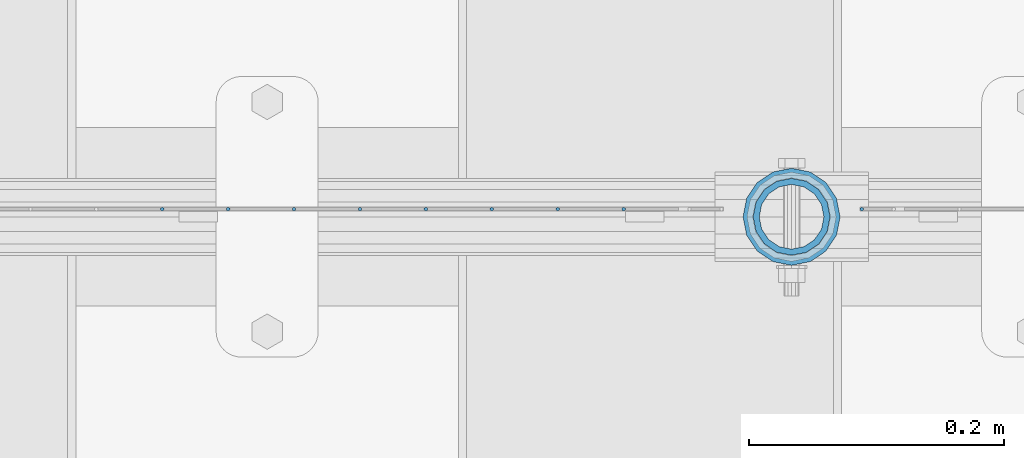
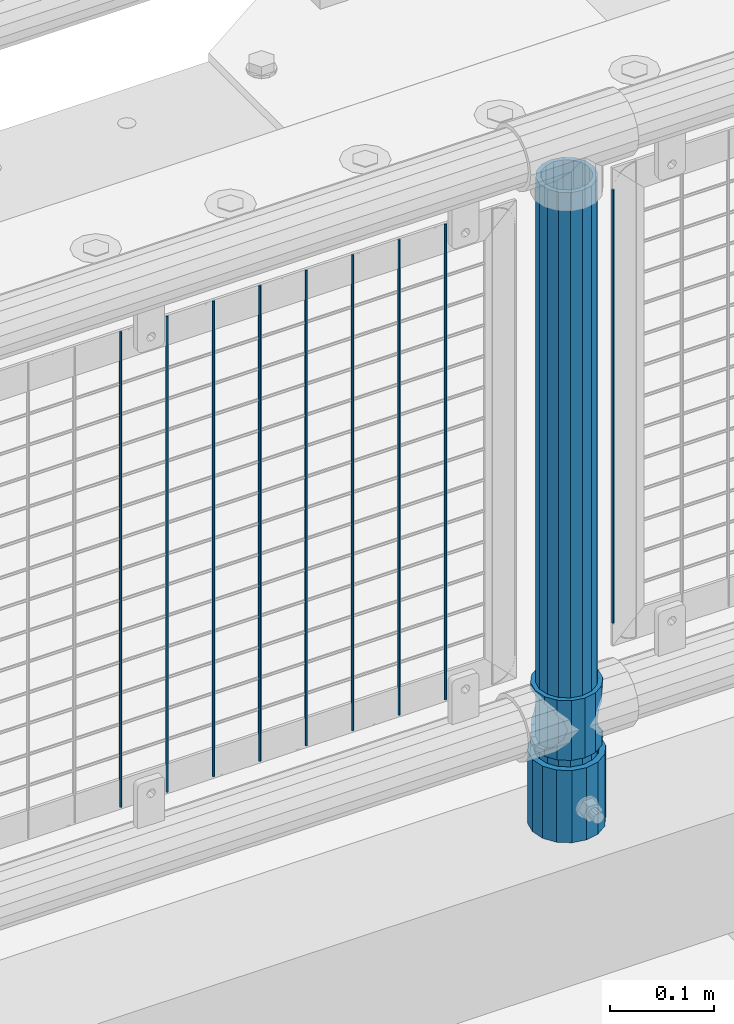
# One storey, part 81 of 219: 12 columns.
"""IFC2X3 building model written with IfcOpenShell, lengths in millimetres."""

from ifc_helpers import new_model, si_unit, frame, origin_with_axes, place, context, subcontext, project, spatial, faceted_brep, material, type_object, element, save


model = new_model("IFC2X3")

# Units and contexts
model_context = context("Model", 3, precision=1e-05, world=origin_with_axes())
body_context = subcontext(model_context, "Body", "Model", "MODEL_VIEW")
ifc_project = project(units=[si_unit("LENGTHUNIT", "METRE", prefix="MILLI"), si_unit("AREAUNIT", "SQUARE_METRE"), si_unit("VOLUMEUNIT", "CUBIC_METRE"), si_unit("MASSUNIT", "GRAM", prefix="KILO"), si_unit("TIMEUNIT", "SECOND"), si_unit("PLANEANGLEUNIT", "RADIAN"), si_unit("SOLIDANGLEUNIT", "STERADIAN"), si_unit("THERMODYNAMICTEMPERATUREUNIT", "DEGREE_CELSIUS"), si_unit("LUMINOUSINTENSITYUNIT", "LUMEN")], contexts=[model_context])

# Site, building, storey
site_placement = place(None, origin_with_axes())
site = spatial("IfcSite", under=ifc_project, at=site_placement, CompositionType="ELEMENT")
building_placement = place(site_placement, origin_with_axes())
building = spatial("IfcBuilding", under=site, at=building_placement, Name="Standard", CompositionType="ELEMENT")
storey_placement = place(building_placement, origin_with_axes())
storey = spatial("IfcBuildingStorey", under=building, at=storey_placement, Name="Undefined", CompositionType="ELEMENT", Elevation=0.0)

# Columns
ifc_material_1 = material(Name="Misc_Undefined")
column_type_1 = type_object("IfcColumnType", PredefinedType="NOTDEFINED")
column_1_placement = place(storey_placement, frame((8911.0, 31664.5, 263.02), z_axis=(-1.0, 0.0, 0.0), x_axis=(0.0, 0.0, 1.0)))
element("IfcColumn", 1, at=column_1_placement, inside=storey, type_object=column_type_1, material=ifc_material_1, context=body_context, shape_type="Brep", body=[
    faceted_brep([(56.6106908090114, 21.46069080901, -21.4606908090118), (56.6106908090114, 21.46069080901, -27.1226768591096), (61.9623795176703, 13.4513226476338, -32.4743655677721), (63.1897438117172, 11.614442172282, -32.8397438117172), (63.1897438117172, 11.614442172282, -28.0397438117179), (46.7644421722801, 28.0397438117179, -11.6144421722802), (46.7644421722801, 28.0397438117179, -20.0882031229849), (51.5310424080006, 24.8548033587067, -24.8548033587067), (35.1499999999996, 30.35, 0.0), (35.1499999999996, 30.3499999999985, -16.6306603983739), (23.5355578277192, 28.0397438117179, -11.6144421722802), (23.5355578277192, 28.0397438117179, -20.0882031229849), (13.6893091909879, 21.46069080901, -21.4606908090118), (13.6893091909879, 21.46069080901, -27.1226768591096), (18.7689575919987, 24.8548033587067, -24.8548033587067), (7.11025618828211, 11.614442172282, -28.0397438117179), (7.11025618828211, 11.614442172282, -32.8397438117172), (8.33762048232455, 13.4513226476338, -32.4743655677721), (4.79999999999961, 0.0, -30.3500000000004), (4.79999999999961, 0.0, -35.1499999999996), (7.11025618828211, -11.614442172282, -28.0397438117179), (7.11025618828211, -11.614442172282, -32.839743811719), (13.6893091909879, -21.46069080901, -21.4606908090118), (13.6893091909879, -21.46069080901, -27.1226768591077), (8.33762048232455, -13.4513226476338, -32.4743655677721), (23.5355578277191, -28.0397438117179, -11.6144421722802), (23.5355578277191, -28.0397438117179, -20.0882031229739), (18.7689575919921, -24.8548033587067, -24.8548033587067), (35.1499999999996, -30.35, 0.0), (35.1499999999996, -30.3499999999985, -16.6306603983649), (46.7644421722801, -28.0397438117179, -11.6144421722802), (46.7644421722801, -28.0397438117179, -20.0882031229739), (56.6106908090114, -21.46069080901, -21.4606908090118), (56.6106908090114, -21.46069080901, -27.1226768591077), (51.5310424080006, -24.8548033587067, -24.8548033587067), (63.1897438117172, -11.614442172282, -28.0397438117179), (63.1897438117172, -11.614442172282, -32.839743811719), (61.9623795176747, -13.4513226476338, -32.4743655677721), (65.4999999999997, 0.0, -30.3500000000004), (65.4999999999997, 0.0, -35.1499999999996), (0.0, -28.0397438117179, -11.6144421722802), (0.0, -30.3499999999985, 0.0), (0.0, -21.46069080901, -21.4606908090118), (0.0, -11.614442172282, -28.0397438117179), (0.0, 0.0, -30.3500000000004), (0.0, 11.614442172282, -28.0397438117179), (0.0, 21.46069080901, -21.4606908090118), (0.0, 28.0397438117179, -11.6144421722802), (0.0, 30.3499999999985, 0.0), (0.0, 28.0397438117179, 11.6144421722802), (23.5355578277192, 28.0397438117179, 11.6144421722806), (0.0, 21.46069080901, 21.4606908090118), (13.6893091909879, 21.46069080901, 21.4606908090118), (0.0, 11.614442172282, 28.0397438117179), (7.11025618828211, 11.614442172282, 28.0397438117175), (0.0, 0.0, 30.3500000000004), (4.79999999999961, 0.0, 30.3499999999999), (0.0, -11.614442172282, 28.0397438117179), (7.11025618828205, -11.614442172282, 28.0397438117175), (0.0, -21.46069080901, 21.4606908090118), (13.6893091909879, -21.46069080901, 21.4606908090118), (0.0, -28.0397438117179, 11.6144421722802), (23.5355578277191, -28.0397438117179, 11.6144421722806), (0.0, -32.4743655677703, 13.4513226476338), (0.0, -35.1500000000015, 0.0), (70.2999999999993, -35.1500000000015, 0.0), (70.2999999999993, -32.4743655677703, 13.4513226476338), (0.0, 13.4513226476338, -32.4743655677721), (0.0, 24.8548033587067, -24.8548033587067), (0.0, 0.0, -35.1500000000015), (0.0, -13.4513226476338, -32.4743655677721), (0.0, -24.8548033587067, -24.8548033587067), (0.0, -24.8548033587067, 24.8548033587067), (0.0, -13.4513226476338, 32.4743655677721), (0.0, 0.0, 35.1500000000015), (0.0, 13.4513226476338, 32.4743655677721), (0.0, 24.8548033587067, 24.8548033587067), (0.0, 32.4743655677703, 13.4513226476338), (0.0, 35.1500000000015, 0.0), (0.0, 32.4743655677703, -13.4513226476338), (0.0, -32.4743655677703, -13.4513226476338), (70.2999999999993, 32.4743655677703, 13.4513226476338), (70.2999999999993, 35.1500000000015, 0.0), (70.2999999999993, 32.4743655677703, -13.4513226476338), (70.2999999999993, 24.8548033587067, -24.8548033587067), (70.2999999999993, 13.4513226476338, -32.4743655677721), (70.2999999999993, 0.0, -35.1499999999996), (70.2999999999993, -13.4513226476338, -32.4743655677721), (70.2999999999993, -24.8548033587067, -24.8548033587067), (70.2999999999993, -32.4743655677703, -13.4513226476338), (70.2999999999993, 28.0397438117179, 11.6144421722802), (70.2999999999993, 21.46069080901, 21.4606908090118), (56.6106908090114, 21.46069080901, 21.4606908090118), (46.7644421722801, 28.0397438117179, 11.6144421722806), (70.2999999999993, 11.614442172282, 28.0397438117179), (63.1897438117172, 11.614442172282, 28.0397438117175), (70.2999999999993, 0.0, 30.3500000000004), (65.4999999999997, 0.0, 30.3499999999999), (70.2999999999993, -11.614442172282, 28.0397438117179), (63.1897438117172, -11.614442172282, 28.0397438117175), (70.2999999999993, -21.46069080901, 21.4606908090118), (56.6106908090114, -21.46069080901, 21.4606908090118), (70.2999999999993, -28.0397438117179, 11.6144421722802), (46.7644421722801, -28.0397438117179, 11.6144421722806), (70.2999999999993, -11.614442172282, -28.0397438117179), (70.2999999999993, 0.0, -30.3500000000004), (70.2999999999993, -21.46069080901, -21.4606908090118), (70.2999999999993, -28.0397438117179, -11.6144421722802), (70.2999999999993, -30.3499999999985, 0.0), (70.2999999999993, 24.8548033587067, 24.8548033587067), (70.2999999999993, 13.4513226476338, 32.4743655677721), (70.2999999999993, 0.0, 35.1499999999996), (70.2999999999993, -13.4513226476338, 32.4743655677721), (70.2999999999993, -24.8548033587067, 24.8548033587067), (70.2999999999993, 30.3499999999985, 0.0), (70.2999999999993, 28.0397438117179, -11.6144421722802), (70.2999999999993, 21.46069080901, -21.4606908090118), (70.2999999999993, 11.614442172282, -28.0397438117179), (61.9623795176742, 13.4513226476338, 32.4743655677717), (51.5310424080006, 24.8548033587067, 24.8548033587072), (56.6106908090114, 21.46069080901, 27.1226768591059), (65.4999999999997, 0.0, 35.1500000000001), (63.1897438117172, 11.614442172282, 32.8397438117177), (63.1897438117172, -11.614442172282, 32.8397438117177), (61.9623795176742, -13.4513226476338, 32.4743655677717), (56.6106908090114, -21.46069080901, 27.1226768591087), (51.5310424080006, -24.8548033587067, 24.8548033587072), (18.7689575919921, -24.8548033587067, 24.8548033587072), (46.7644421722801, -28.0397438117179, 20.0882031229862), (35.1499999999996, -30.3499999999985, 16.630660398373), (23.5355578277191, -28.0397438117179, 20.0882031229862), (8.33762048232506, -13.4513226476338, 32.4743655677717), (13.6893091909879, -21.46069080901, 27.1226768591087), (4.79999999999961, 0.0, 35.1500000000001), (7.11025618828205, -11.614442172282, 32.8397438117177), (7.11025618828211, 11.614442172282, 32.8397438117177), (8.33762048232069, 13.4513226476338, 32.4743655677717), (13.6893091909879, 21.46069080901, 27.1226768591059), (18.7689575919987, 24.8548033587067, 24.8548033587072), (23.5355578277192, 28.0397438117179, 20.0882031229794), (35.1499999999996, 30.3499999999985, 16.6306603983667), (46.7644421722801, 28.0397438117179, 20.0882031229794)], [[[0, 1, 2, 3, 4]], [[5, 6, 7, 1, 0]], [[8, 9, 6, 5]], [[10, 11, 9, 8]], [[12, 13, 14, 11, 10]], [[15, 16, 17, 13, 12]], [[18, 19, 16, 15]], [[20, 21, 19, 18]], [[22, 23, 24, 21, 20]], [[25, 26, 27, 23, 22]], [[28, 29, 26, 25]], [[30, 31, 29, 28]], [[32, 33, 34, 31, 30]], [[35, 36, 37, 33, 32]], [[38, 39, 36, 35]], [[4, 3, 39, 38]], [[40, 41, 28, 25]], [[42, 40, 25, 22]], [[43, 42, 22, 20]], [[44, 43, 20, 18]], [[45, 44, 18, 15]], [[46, 45, 15, 12]], [[47, 46, 12, 10]], [[48, 47, 10, 8]], [[49, 48, 8, 50]], [[51, 49, 50, 52]], [[53, 51, 52, 54]], [[55, 53, 54, 56]], [[57, 55, 56, 58]], [[59, 57, 58, 60]], [[61, 59, 60, 62]], [[41, 61, 62, 28]], [[63, 64, 65, 66]], [[17, 67, 68, 14, 13]], [[19, 69, 67, 17, 16]], [[70, 69, 19, 21, 24]], [[71, 70, 24, 23, 27]], [[63, 72, 73, 74, 75, 76, 77, 78, 79, 68, 67, 69, 70, 71, 80, 64], [40, 42, 43, 44, 45, 46, 47, 48, 49, 51, 53, 55, 57, 59, 61, 41]], [[78, 77, 81, 82]], [[79, 78, 82, 83]], [[14, 68, 79, 83, 84, 7, 6, 9, 11]], [[84, 85, 2, 1, 7]], [[85, 86, 39, 3, 2]], [[37, 87, 88, 34, 33]], [[39, 86, 87, 37, 36]], [[34, 88, 89, 80, 71, 27, 26, 29, 31]], [[64, 80, 89, 65]], [[90, 91, 92, 93]], [[91, 94, 95, 92]], [[94, 96, 97, 95]], [[96, 98, 99, 97]], [[98, 100, 101, 99]], [[100, 102, 103, 101]], [[104, 105, 38, 35]], [[106, 104, 35, 32]], [[107, 106, 32, 30]], [[108, 107, 30, 28]], [[102, 108, 28, 103]], [[88, 87, 86, 85, 84, 83, 82, 81, 109, 110, 111, 112, 113, 66, 65, 89], [100, 98, 96, 94, 91, 90, 114, 115, 116, 117, 105, 104, 106, 107, 108, 102]], [[118, 110, 109, 119, 120]], [[121, 111, 110, 118, 122]], [[112, 111, 121, 123, 124]], [[113, 112, 124, 125, 126]], [[127, 72, 63, 66, 113, 126, 128, 129, 130]], [[131, 73, 72, 127, 132]], [[133, 74, 73, 131, 134]], [[75, 74, 133, 135, 136]], [[76, 75, 136, 137, 138]], [[119, 109, 81, 77, 76, 138, 139, 140, 141]], [[92, 120, 119, 141, 93]], [[95, 122, 118, 120, 92]], [[97, 121, 122, 95]], [[99, 123, 121, 97]], [[101, 125, 124, 123, 99]], [[103, 128, 126, 125, 101]], [[28, 129, 128, 103]], [[62, 130, 129, 28]], [[60, 132, 127, 130, 62]], [[58, 134, 131, 132, 60]], [[56, 133, 134, 58]], [[54, 135, 133, 56]], [[52, 137, 136, 135, 54]], [[50, 139, 138, 137, 52]], [[8, 140, 139, 50]], [[93, 141, 140, 8]], [[114, 90, 93, 8]], [[115, 114, 8, 5]], [[116, 115, 5, 0]], [[117, 116, 0, 4]], [[105, 117, 4, 38]]]),
])
ifc_material_2 = material()
column_type_2 = type_object("IfcColumnType", PredefinedType="NOTDEFINED")
column_2_placement = place(storey_placement, frame((8911.0, 31664.5, 168.02), z_axis=(-1.0, 0.0, 0.0), x_axis=(0.0, 0.0, 1.0)))
element("IfcColumn", 2, at=column_2_placement, inside=storey, type_object=column_type_2, material=ifc_material_2, context=body_context, shape_type="Brep", body=[
    faceted_brep([(0.0, -25.3499999999985, 0.0), (0.0, -23.4203461491597, 9.70102501045585), (760.0, -23.4203461491597, 9.70102501045585), (760.0, -25.3499999999985, 0.0), (0.0, -17.9251569030785, 17.9251569030785), (760.0, -17.9251569030785, 17.9251569030785), (0.0, -9.70102501045403, 23.4203461491616), (760.0, -9.70102501045403, 23.4203461491616), (0.0, 0.0, 25.3500000000004), (760.0, 0.0, 25.3500000000004), (0.0, 9.70102501045403, 23.4203461491616), (760.0, 9.70102501045403, 23.4203461491616), (0.0, 17.9251569030785, 17.9251569030785), (760.0, 17.9251569030785, 17.9251569030785), (0.0, 23.4203461491597, 9.70102501045585), (760.0, 23.4203461491597, 9.70102501045585), (0.0, 25.3499999999985, 0.0), (760.0, 25.3499999999985, 0.0), (0.0, 23.4203461491597, -9.70102501045585), (760.0, 23.4203461491597, -9.70102501045585), (0.0, 17.9251569030785, -17.9251569030785), (760.0, 17.9251569030785, -17.9251569030785), (0.0, 9.70102501045403, -23.4203461491616), (760.0, 9.70102501045403, -23.4203461491616), (0.0, 0.0, -25.3500000000004), (760.0, 0.0, -25.3500000000004), (0.0, -9.70102501045403, -23.4203461491616), (760.0, -9.70102501045403, -23.4203461491616), (0.0, -17.9251569030785, -17.9251569030785), (760.0, -17.9251569030785, -17.9251569030785), (0.0, -23.4203461491597, -9.70102501045585), (760.0, -23.4203461491597, -9.70102501045585), (0.0, -30.1500000000015, 0.0), (0.0, -27.8549679052157, -11.5379054858076), (760.0, -27.8549679052157, -11.5379054858076), (760.0, -30.1500000000015, 0.0), (0.0, -21.3192694527752, -21.3192694527752), (760.0, -21.3192694527752, -21.3192694527752), (0.0, -11.5379054858058, -27.8549679052157), (760.0, -11.5379054858058, -27.8549679052157), (0.0, 0.0, -30.1499999999996), (760.0, 0.0, -30.1499999999996), (0.0, 11.5379054858058, -27.8549679052157), (760.0, 11.5379054858058, -27.8549679052157), (0.0, 21.3192694527752, -21.3192694527752), (760.0, 21.3192694527752, -21.3192694527752), (0.0, 27.8549679052157, -11.5379054858076), (760.0, 27.8549679052157, -11.5379054858076), (0.0, 30.1500000000015, 0.0), (760.0, 30.1500000000015, 0.0), (0.0, 27.8549679052157, 11.5379054858076), (760.0, 27.8549679052157, 11.5379054858076), (0.0, 21.3192694527752, 21.3192694527752), (760.0, 21.3192694527752, 21.3192694527752), (0.0, 11.5379054858058, 27.8549679052157), (760.0, 11.5379054858058, 27.8549679052157), (0.0, 0.0, 30.1499999999996), (760.0, 0.0, 30.1499999999996), (0.0, -11.5379054858058, 27.8549679052157), (760.0, -11.5379054858058, 27.8549679052157), (0.0, -21.3192694527752, 21.3192694527752), (760.0, -21.3192694527752, 21.3192694527752), (0.0, -27.8549679052157, 11.5379054858076), (760.0, -27.8549679052157, 11.5379054858076)], [[[0, 1, 2, 3]], [[1, 4, 5, 2]], [[4, 6, 7, 5]], [[6, 8, 9, 7]], [[8, 10, 11, 9]], [[10, 12, 13, 11]], [[12, 14, 15, 13]], [[14, 16, 17, 15]], [[16, 18, 19, 17]], [[18, 20, 21, 19]], [[20, 22, 23, 21]], [[22, 24, 25, 23]], [[24, 26, 27, 25]], [[26, 28, 29, 27]], [[28, 30, 31, 29]], [[30, 0, 3, 31]], [[32, 33, 34, 35]], [[33, 36, 37, 34]], [[36, 38, 39, 37]], [[38, 40, 41, 39]], [[40, 42, 43, 41]], [[42, 44, 45, 43]], [[44, 46, 47, 45]], [[46, 48, 49, 47]], [[48, 50, 51, 49]], [[50, 52, 53, 51]], [[52, 54, 55, 53]], [[54, 56, 57, 55]], [[56, 58, 59, 57]], [[58, 60, 61, 59]], [[60, 62, 63, 61]], [[62, 32, 35, 63]], [[37, 39, 41, 43, 45, 47, 49, 51, 53, 55, 57, 59, 61, 63, 35, 34], [5, 7, 9, 11, 13, 15, 17, 19, 21, 23, 25, 27, 29, 31, 3, 2]], [[62, 60, 58, 56, 54, 52, 50, 48, 46, 44, 42, 40, 38, 36, 33, 32], [30, 28, 26, 24, 22, 20, 18, 16, 14, 12, 10, 8, 6, 4, 1, 0]]]),
])
column_type_3 = type_object("IfcColumnType", PredefinedType="NOTDEFINED")
column_3_placement = place(storey_placement, frame((8911.0, 31664.5, 168.02), z_axis=(0.0, 1.0, 0.0), x_axis=(0.0, 0.0, 1.0)))
element("IfcColumn", 3, at=column_3_placement, inside=storey, type_object=column_type_3, material=ifc_material_2, context=body_context, shape_type="Brep", body=[
    faceted_brep([(0.0, -31.75, 0.0), (0.0, -29.3331751572332, 12.1501989775934), (85.0, -29.3331751572332, 12.1501989775934), (85.0, -31.75, 0.0), (0.0, -22.4506403026735, 22.4506403026717), (85.0, -22.4506403026735, 22.4506403026717), (0.0, -12.1501989775916, 29.3331751572332), (85.0, -12.1501989775916, 29.3331751572332), (0.0, 0.0, 31.75), (85.0, 0.0, 31.75), (0.0, 12.1501989775916, 29.3331751572332), (85.0, 12.1501989775916, 29.3331751572332), (0.0, 22.4506403026735, 22.4506403026717), (85.0, 22.4506403026735, 22.4506403026717), (0.0, 29.3331751572332, 12.1501989775934), (85.0, 29.3331751572332, 12.1501989775934), (0.0, 31.75, 0.0), (85.0, 31.75, 0.0), (0.0, 29.3331751572332, -12.1501989775934), (85.0, 29.3331751572332, -12.1501989775934), (0.0, 22.4506403026735, -22.4506403026717), (85.0, 22.4506403026735, -22.4506403026717), (0.0, 12.1501989775916, -29.3331751572332), (85.0, 12.1501989775916, -29.3331751572332), (0.0, 0.0, -31.75), (85.0, 0.0, -31.75), (0.0, -12.1501989775916, -29.3331751572332), (85.0, -12.1501989775916, -29.3331751572332), (0.0, -22.4506403026735, -22.4506403026717), (85.0, -22.4506403026735, -22.4506403026717), (0.0, -29.3331751572332, -12.1501989775934), (85.0, -29.3331751572332, -12.1501989775934), (0.0, -38.0499999999993, 0.0), (0.0, -35.1536162120537, -14.5611046014928), (85.0, -35.1536162120537, -14.5611046014928), (85.0, -38.0499999999993, 0.0), (0.0, -26.9054130241475, -26.9054130241493), (85.0, -26.9054130241475, -26.9054130241493), (0.0, -14.561104601491, -35.1536162120537), (85.0, -14.561104601491, -35.1536162120537), (0.0, 0.0, -38.0499999999993), (85.0, 0.0, -38.0499999999993), (0.0, 14.561104601491, -35.1536162120537), (85.0, 14.561104601491, -35.1536162120537), (0.0, 26.9054130241475, -26.9054130241493), (85.0, 26.9054130241475, -26.9054130241493), (0.0, 35.1536162120537, -14.5611046014928), (85.0, 35.1536162120537, -14.5611046014928), (0.0, 38.0499999999993, 0.0), (85.0, 38.0499999999993, 0.0), (0.0, 35.1536162120537, 14.5611046014928), (85.0, 35.1536162120537, 14.5611046014928), (0.0, 26.9054130241475, 26.9054130241493), (85.0, 26.9054130241475, 26.9054130241493), (0.0, 14.561104601491, 35.1536162120537), (85.0, 14.561104601491, 35.1536162120537), (0.0, 0.0, 38.0499999999993), (85.0, 0.0, 38.0499999999993), (0.0, -14.561104601491, 35.1536162120537), (85.0, -14.561104601491, 35.1536162120537), (0.0, -26.9054130241475, 26.9054130241493), (85.0, -26.9054130241475, 26.9054130241493), (0.0, -35.1536162120537, 14.5611046014928), (85.0, -35.1536162120537, 14.5611046014928)], [[[0, 1, 2, 3]], [[1, 4, 5, 2]], [[4, 6, 7, 5]], [[6, 8, 9, 7]], [[8, 10, 11, 9]], [[10, 12, 13, 11]], [[12, 14, 15, 13]], [[14, 16, 17, 15]], [[16, 18, 19, 17]], [[18, 20, 21, 19]], [[20, 22, 23, 21]], [[22, 24, 25, 23]], [[24, 26, 27, 25]], [[26, 28, 29, 27]], [[28, 30, 31, 29]], [[30, 0, 3, 31]], [[32, 33, 34, 35]], [[33, 36, 37, 34]], [[36, 38, 39, 37]], [[38, 40, 41, 39]], [[40, 42, 43, 41]], [[42, 44, 45, 43]], [[44, 46, 47, 45]], [[46, 48, 49, 47]], [[48, 50, 51, 49]], [[50, 52, 53, 51]], [[52, 54, 55, 53]], [[54, 56, 57, 55]], [[56, 58, 59, 57]], [[58, 60, 61, 59]], [[60, 62, 63, 61]], [[62, 32, 35, 63]], [[37, 39, 41, 43, 45, 47, 49, 51, 53, 55, 57, 59, 61, 63, 35, 34], [5, 7, 9, 11, 13, 15, 17, 19, 21, 23, 25, 27, 29, 31, 3, 2]], [[62, 60, 58, 56, 54, 52, 50, 48, 46, 44, 42, 40, 38, 36, 33, 32], [30, 28, 26, 24, 22, 20, 18, 16, 14, 12, 10, 8, 6, 4, 1, 0]]]),
])
column_type_4 = type_object("IfcColumnType", Name="D3", PredefinedType="NOTDEFINED")
column_4_placement = place(storey_placement, frame((8966.0, 31670.5, 378.020000000001), z_axis=(-1.0, 0.0, 0.0), x_axis=(0.0, 0.0, 1.0)))
element("IfcColumn", 4, at=column_4_placement, inside=storey, type_object=column_type_4, material=ifc_material_1, ObjectType="D3", context=body_context, shape_type="Brep", body=[
    faceted_brep([(0.0, -1.5, -5.6843418860808e-14), (0.0, -0.75, -1.29903810567669), (510.0, -0.75, -1.29903810567703), (510.0, -1.5, 0.0), (0.0, 0.75, -1.29903810567669), (510.0, 0.75, -1.29903810567703), (0.0, 1.5, -5.6843418860808e-14), (510.0, 1.5, 0.0), (0.0, 0.75, 1.29903810567669), (510.0, 0.75, 1.29903810567703), (0.0, -0.75, 1.29903810567669), (510.0, -0.75, 1.29903810567703)], [[[0, 1, 2, 3]], [[1, 4, 5, 2]], [[4, 6, 7, 5]], [[6, 8, 9, 7]], [[8, 10, 11, 9]], [[10, 0, 3, 11]], [[5, 7, 9, 11, 3, 2]], [[10, 8, 6, 4, 1, 0]]]),
])
for number, where, z_axis, x_axis in (
    (5, (8779.34, 31670.5, 353.020000000001), (-1.0, 0.0, 0.0), (0.0, 0.0, 1.0)),
    (6, (8727.685, 31670.5, 353.020000000001), (-1.0, 0.0, 0.0), (0.0, 0.0, 1.0)),
    (7, (8676.03, 31670.5, 353.020000000001), (-1.0, 0.0, 0.0), (0.0, 0.0, 1.0)),
    (8, (8624.375, 31670.5, 353.020000000001), (-1.0, 0.0, 0.0), (0.0, 0.0, 1.0)),
    (9, (8572.72, 31670.5, 353.020000000001), (-1.0, 0.0, 0.0), (0.0, 0.0, 1.0)),
    (10, (8521.065, 31670.5, 353.020000000001), (-1.0, 0.0, 0.0), (0.0, 0.0, 1.0)),
    (11, (8469.41, 31670.5, 353.020000000001), (-1.0, 0.0, 0.0), (0.0, 0.0, 1.0)),
    (12, (8417.755, 31670.5, 353.020000000001), (-1.0, 0.0, 0.0), (0.0, 0.0, 1.0)),
):
    element("IfcColumn", number, at=place(storey_placement, frame(where, z_axis=z_axis, x_axis=x_axis)), inside=storey, type_object=column_type_4, material=ifc_material_1, ObjectType="D3", context=body_context, shape_type="Brep", body=[
        faceted_brep([(0.0, -1.5, -5.6843418860808e-14), (0.0, -0.75, -1.29903810567669), (560.0, -0.75, -1.29903810567703), (560.0, -1.5, 0.0), (0.0, 0.75, -1.29903810567669), (560.0, 0.75, -1.29903810567703), (0.0, 1.5, -5.6843418860808e-14), (560.0, 1.5, 0.0), (0.0, 0.75, 1.29903810567669), (560.0, 0.75, 1.29903810567703), (0.0, -0.75, 1.29903810567669), (560.0, -0.75, 1.29903810567703)], [[[0, 1, 2, 3]], [[1, 4, 5, 2]], [[4, 6, 7, 5]], [[6, 8, 9, 7]], [[8, 10, 11, 9]], [[10, 0, 3, 11]], [[5, 7, 9, 11, 3, 2]], [[10, 8, 6, 4, 1, 0]]]),
    ])

save(model, "model.ifc")
